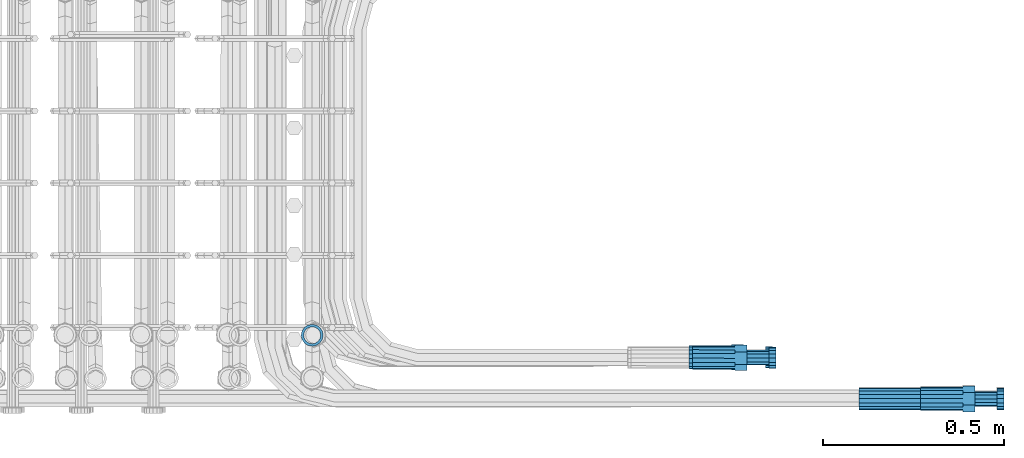
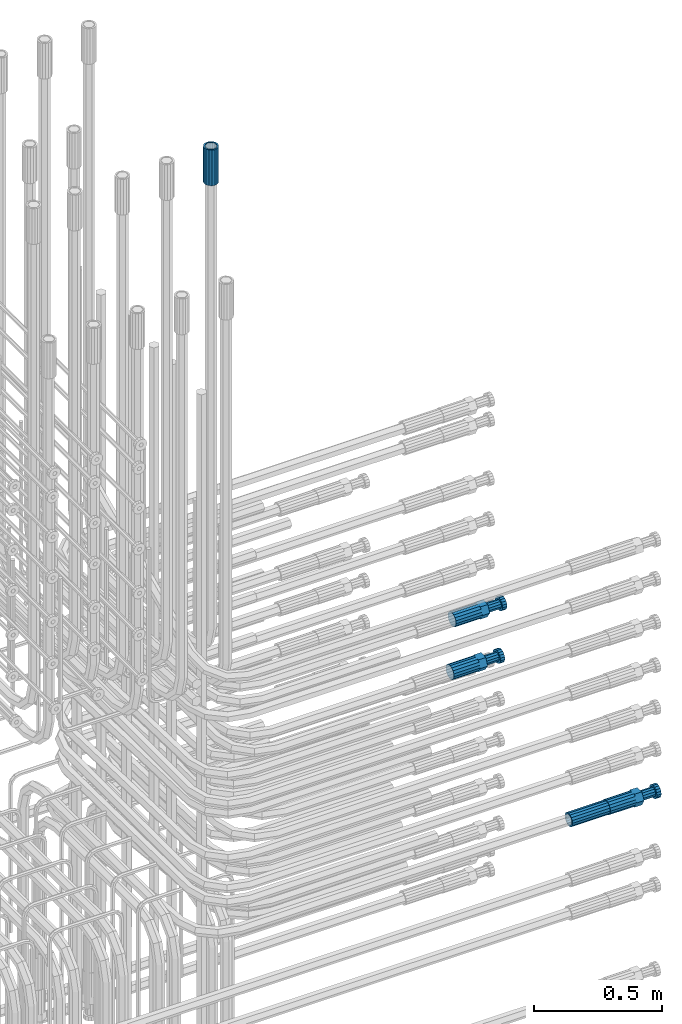
# One storey, part 101 of 177: 5 beams.
"""IFC2X3 building model written with IfcOpenShell, lengths in millimetres."""

from ifc_helpers import new_model, si_unit, frame, origin_with_axes, place, context, subcontext, project, spatial, faceted_brep, material, type_object, element, save


model = new_model("IFC2X3")

# Units and contexts
model_context_1 = context("Model", 3, precision=1e-05, world=origin_with_axes())
model_context_2 = context("Model", 3, precision=1e-05, world=origin_with_axes())
body_context = subcontext(model_context_2, "Body", "Model", "MODEL_VIEW")
ifc_project = project(units=[si_unit("LENGTHUNIT", "METRE", prefix="MILLI"), si_unit("AREAUNIT", "SQUARE_METRE"), si_unit("VOLUMEUNIT", "CUBIC_METRE"), si_unit("MASSUNIT", "GRAM", prefix="KILO"), si_unit("TIMEUNIT", "SECOND"), si_unit("PLANEANGLEUNIT", "RADIAN"), si_unit("SOLIDANGLEUNIT", "STERADIAN"), si_unit("THERMODYNAMICTEMPERATUREUNIT", "DEGREE_CELSIUS"), si_unit("LUMINOUSINTENSITYUNIT", "LUMEN")], contexts=[model_context_1])

# Site, building, storey
site_placement = place(None, origin_with_axes())
site = spatial("IfcSite", under=ifc_project, at=site_placement, CompositionType="ELEMENT")
building_placement = place(site_placement, origin_with_axes())
building = spatial("IfcBuilding", under=site, at=building_placement, Name="Undefined", CompositionType="ELEMENT")
storey_placement = place(building_placement, origin_with_axes())
storey = spatial("IfcBuildingStorey", under=building, at=storey_placement, Name="Undefined", CompositionType="ELEMENT", Elevation=0.0)

# Beams
ifc_material = material(Name="STEEL/S275")
beam_type_1 = type_object("IfcBeamType", PredefinedType="NOTDEFINED")
beam_1_placement = place(storey_placement, frame((2039349.51584447, 6205098.06535392, 19760.1899362774), z_axis=(0.0, -0.0174524050028996, -0.999847695181429), x_axis=(1.0, 0.0, 0.0)))
element("IfcBeam", 1, at=beam_1_placement, inside=storey, type_object=beam_type_1, material=ifc_material, Name="AG40N", context=body_context, shape_type="Brep", body=[
    faceted_brep([(0.0, -23.5000000001164, -9.31322574615479e-10), (0.0, -21.7111690140155, 8.99306066054851), (170.0, -21.7111690140155, 8.99306066054851), (170.0, -23.5, 0.0), (0.0, -16.6170093578839, 16.6170093575493), (170.0, -16.6170093578839, 16.6170093575493), (0.0, -8.99306066057943, 21.7111690137535), (170.0, -8.99306066057943, 21.7111690137535), (0.0, 1.16415321826935e-10, 23.5), (170.0, 0.0, 23.5), (0.0, 8.99306066057943, 21.7111690137535), (170.0, 8.99306066057943, 21.7111690137535), (0.0, 16.6170093578839, 16.6170093575493), (170.0, 16.6170093578839, 16.6170093575493), (0.0, 21.7111690140155, 8.99306066054851), (170.0, 21.7111690140155, 8.99306066054851), (0.0, 23.5000000001164, -9.31322574615479e-10), (170.0, 23.5, 0.0), (0.0, 21.7111690140155, -8.99306066054851), (170.0, 21.7111690140155, -8.99306066054851), (0.0, 16.6170093578839, -16.6170093575493), (170.0, 16.6170093578839, -16.6170093575493), (0.0, 8.99306066057943, -21.7111690137535), (170.0, 8.99306066057943, -21.7111690137535), (0.0, 1.16415321826935e-10, -23.5000000009313), (170.0, 0.0, -23.5), (0.0, -8.99306066057943, -21.7111690137535), (170.0, -8.99306066057943, -21.7111690137535), (0.0, -16.6170093578839, -16.6170093575493), (170.0, -16.6170093578839, -16.6170093575493), (0.0, -21.7111690140155, -8.99306066054851), (170.0, -21.7111690140155, -8.99306066054851), (0.0, -30.5, 0.0), (0.0, -28.1783257415937, -11.6718446873128), (170.0, -28.1783257415937, -11.6718446873128), (170.0, -30.5, 0.0), (0.0, -21.5667568261888, -21.5667568258941), (170.0, -21.5667568261888, -21.5667568258941), (0.0, -11.6718446871346, -28.1783257415518), (170.0, -11.6718446871346, -28.1783257415518), (0.0, 0.0, -30.5), (170.0, 0.0, -30.5), (0.0, 11.6718446871346, -28.1783257415518), (170.0, 11.6718446871346, -28.1783257415518), (0.0, 21.5667568261888, -21.5667568258941), (170.0, 21.5667568261888, -21.5667568258941), (0.0, 28.1783257415937, -11.6718446873128), (170.0, 28.1783257415937, -11.6718446873128), (0.0, 30.5, 0.0), (170.0, 30.5, 0.0), (0.0, 28.1783257415937, 11.6718446873128), (170.0, 28.1783257415937, 11.6718446873128), (0.0, 21.5667568261888, 21.5667568258941), (170.0, 21.5667568261888, 21.5667568258941), (0.0, 11.6718446871346, 28.1783257415518), (170.0, 11.6718446871346, 28.1783257415518), (0.0, 0.0, 30.5), (170.0, 0.0, 30.5), (0.0, -11.6718446871346, 28.1783257415518), (170.0, -11.6718446871346, 28.1783257415518), (0.0, -21.5667568261888, 21.5667568258941), (170.0, -21.5667568261888, 21.5667568258941), (0.0, -28.1783257415937, 11.6718446873128), (170.0, -28.1783257415937, 11.6718446873128)], [[[0, 1, 2, 3]], [[1, 4, 5, 2]], [[4, 6, 7, 5]], [[6, 8, 9, 7]], [[8, 10, 11, 9]], [[10, 12, 13, 11]], [[12, 14, 15, 13]], [[14, 16, 17, 15]], [[16, 18, 19, 17]], [[18, 20, 21, 19]], [[20, 22, 23, 21]], [[22, 24, 25, 23]], [[24, 26, 27, 25]], [[26, 28, 29, 27]], [[28, 30, 31, 29]], [[30, 0, 3, 31]], [[32, 33, 34, 35]], [[33, 36, 37, 34]], [[36, 38, 39, 37]], [[38, 40, 41, 39]], [[40, 42, 43, 41]], [[42, 44, 45, 43]], [[44, 46, 47, 45]], [[46, 48, 49, 47]], [[48, 50, 51, 49]], [[50, 52, 53, 51]], [[52, 54, 55, 53]], [[54, 56, 57, 55]], [[56, 58, 59, 57]], [[58, 60, 61, 59]], [[60, 62, 63, 61]], [[62, 32, 35, 63]], [[37, 39, 41, 43, 45, 47, 49, 51, 53, 55, 57, 59, 61, 63, 35, 34], [5, 7, 9, 11, 13, 15, 17, 19, 21, 23, 25, 27, 29, 31, 3, 2]], [[62, 60, 58, 56, 54, 52, 50, 48, 46, 44, 42, 40, 38, 36, 33, 32], [30, 28, 26, 24, 22, 20, 18, 16, 14, 12, 10, 8, 6, 4, 1, 0]]]),
])
beam_2_placement = place(storey_placement, frame((2037835.98583793, 6205274.18965057, 23229.9909142034), z_axis=(1.0, 0.0, 0.0), x_axis=(0.0, 0.0, 1.0)))
element("IfcBeam", 2, at=beam_2_placement, inside=storey, type_object=beam_type_1, material=ifc_material, Name="AG40N", context=body_context, shape_type="Brep", body=[
    faceted_brep([(0.0, -23.5000000001164, -9.31322574615479e-10), (0.0, -21.7111690140155, 8.99306066054851), (170.0, -21.7111690140155, 8.99306066054851), (170.0, -23.5, 0.0), (0.0, -16.6170093578839, 16.6170093575493), (170.0, -16.6170093578839, 16.6170093575493), (0.0, -8.99306066057943, 21.7111690137535), (170.0, -8.99306066057943, 21.7111690137535), (0.0, 1.16415321826935e-10, 23.5), (170.0, 0.0, 23.5), (0.0, 8.99306066057943, 21.7111690137535), (170.0, 8.99306066057943, 21.7111690137535), (0.0, 16.6170093578839, 16.6170093575493), (170.0, 16.6170093578839, 16.6170093575493), (0.0, 21.7111690140155, 8.99306066054851), (170.0, 21.7111690140155, 8.99306066054851), (0.0, 23.5000000001164, -9.31322574615479e-10), (170.0, 23.5, 0.0), (0.0, 21.7111690140155, -8.99306066054851), (170.0, 21.7111690140155, -8.99306066054851), (0.0, 16.6170093578839, -16.6170093575493), (170.0, 16.6170093578839, -16.6170093575493), (0.0, 8.99306066057943, -21.7111690137535), (170.0, 8.99306066057943, -21.7111690137535), (0.0, 1.16415321826935e-10, -23.5000000009313), (170.0, 0.0, -23.5), (0.0, -8.99306066057943, -21.7111690137535), (170.0, -8.99306066057943, -21.7111690137535), (0.0, -16.6170093578839, -16.6170093575493), (170.0, -16.6170093578839, -16.6170093575493), (0.0, -21.7111690140155, -8.99306066054851), (170.0, -21.7111690140155, -8.99306066054851), (0.0, -30.5, 0.0), (0.0, -28.1783257415937, -11.6718446873128), (170.0, -28.1783257415937, -11.6718446873128), (170.0, -30.5, 0.0), (0.0, -21.5667568261888, -21.5667568258941), (170.0, -21.5667568261888, -21.5667568258941), (0.0, -11.6718446871346, -28.1783257415518), (170.0, -11.6718446871346, -28.1783257415518), (0.0, 0.0, -30.5), (170.0, 0.0, -30.5), (0.0, 11.6718446871346, -28.1783257415518), (170.0, 11.6718446871346, -28.1783257415518), (0.0, 21.5667568261888, -21.5667568258941), (170.0, 21.5667568261888, -21.5667568258941), (0.0, 28.1783257415937, -11.6718446873128), (170.0, 28.1783257415937, -11.6718446873128), (0.0, 30.5, 0.0), (170.0, 30.5, 0.0), (0.0, 28.1783257415937, 11.6718446873128), (170.0, 28.1783257415937, 11.6718446873128), (0.0, 21.5667568261888, 21.5667568258941), (170.0, 21.5667568261888, 21.5667568258941), (0.0, 11.6718446871346, 28.1783257415518), (170.0, 11.6718446871346, 28.1783257415518), (0.0, 0.0, 30.5), (170.0, 0.0, 30.5), (0.0, -11.6718446871346, 28.1783257415518), (170.0, -11.6718446871346, 28.1783257415518), (0.0, -21.5667568261888, 21.5667568258941), (170.0, -21.5667568261888, 21.5667568258941), (0.0, -28.1783257415937, 11.6718446873128), (170.0, -28.1783257415937, 11.6718446873128)], [[[0, 1, 2, 3]], [[1, 4, 5, 2]], [[4, 6, 7, 5]], [[6, 8, 9, 7]], [[8, 10, 11, 9]], [[10, 12, 13, 11]], [[12, 14, 15, 13]], [[14, 16, 17, 15]], [[16, 18, 19, 17]], [[18, 20, 21, 19]], [[20, 22, 23, 21]], [[22, 24, 25, 23]], [[24, 26, 27, 25]], [[26, 28, 29, 27]], [[28, 30, 31, 29]], [[30, 0, 3, 31]], [[32, 33, 34, 35]], [[33, 36, 37, 34]], [[36, 38, 39, 37]], [[38, 40, 41, 39]], [[40, 42, 43, 41]], [[42, 44, 45, 43]], [[44, 46, 47, 45]], [[46, 48, 49, 47]], [[48, 50, 51, 49]], [[50, 52, 53, 51]], [[52, 54, 55, 53]], [[54, 56, 57, 55]], [[56, 58, 59, 57]], [[58, 60, 61, 59]], [[60, 62, 63, 61]], [[62, 32, 35, 63]], [[37, 39, 41, 43, 45, 47, 49, 51, 53, 55, 57, 59, 61, 63, 35, 34], [5, 7, 9, 11, 13, 15, 17, 19, 21, 23, 25, 27, 29, 31, 3, 2]], [[62, 60, 58, 56, 54, 52, 50, 48, 46, 44, 42, 40, 38, 36, 33, 32], [30, 28, 26, 24, 22, 20, 18, 16, 14, 12, 10, 8, 6, 4, 1, 0]]]),
])
beam_type_2 = type_object("IfcBeamType", Name="ROD65", PredefinedType="NOTDEFINED")
beam_3_placement = place(storey_placement, frame((2039519.51584447, 6205098.06535392, 19760.1899362774), z_axis=(0.0, -0.0174524050028996, -0.999847695181429), x_axis=(1.0, 0.0, 0.0)))
element("IfcBeam", 3, at=beam_3_placement, inside=storey, type_object=beam_type_2, material=ifc_material, Name="AGB40", ObjectType="ROD65", context=body_context, shape_type="Brep", body=[
    faceted_brep([(117.0, 8.17543110251427, 30.873805644922), (117.0, 17.8250000001863, 30.873805644922), (117.0, 22.0056958701462, 23.6326279877685), (117.0, 12.4372115517035, 30.0260848065373), (117.0, -17.8250000001863, 30.873805644922), (150.200000000186, -17.8250000001863, 30.873805644922), (150.200000000186, 17.8250000001863, 30.873805644922), (117.0, -8.17543110251427, 30.873805644922), (117.0, -12.4372115517035, 30.0260848065373), (117.0, -22.0056958701462, 23.6326279877685), (117.0, -35.6500000003725, 0.0), (150.200000000186, -35.6500000003725, 0.0), (117.0, -30.8443150008097, 8.32369058486074), (117.0, -32.5, 0.0), (117.0, -30.8443150008097, -8.32369058462791), (117.0, -17.8250000001863, -30.873805644922), (150.200000000186, -17.8250000001863, -30.873805644922), (117.0, -22.0056958701462, -23.6326279877685), (117.0, -12.4372115517035, -30.0260848065373), (117.0, -8.17543110251427, -30.873805644922), (117.0, 17.8250000001863, -30.873805644922), (150.200000000186, 17.8250000001863, -30.873805644922), (117.0, 8.17543110251427, -30.873805644922), (117.0, 22.0056958701462, -23.6326279877685), (117.0, 12.4372115517035, -30.0260848065373), (117.0, 35.6500000003725, 0.0), (150.200000000186, 35.6500000003725, 0.0), (117.0, 30.8443150008097, -8.32369058486074), (117.0, 30.8443150008097, 8.32369058462791), (117.0, 32.5, 0.0), (0.0, -22.9809703892097, 22.9809703885621), (0.0, -30.0260848058388, 12.4372115518636), (117.0, -30.0260848067701, 12.4372115519363), (117.0, -22.9809703882784, 22.9809703885112), (-2.3283064365387e-10, 22.9809703892097, -22.9809703885639), (-4.65661287307739e-10, 30.0260848077014, -12.4372115518672), (117.0, 30.0260848067701, -12.4372115519363), (117.0, 22.9809703882784, -22.9809703885112), (-2.3283064365387e-10, -30.0260848067701, -12.4372115518672), (-2.3283064365387e-10, -22.9809703892097, -22.9809703885621), (117.0, -22.9809703882784, -22.9809703885112), (117.0, -30.0260848067701, -12.4372115519363), (-2.3283064365387e-10, -12.4372115507722, 30.0260848066137), (-2.3283064365387e-10, 9.31322574615479e-10, 32.4999999999982), (-2.3283064365387e-10, 12.4372115526348, 30.0260848066137), (0.0, 22.9809703892097, 22.9809703885621), (-2.3283064365387e-10, 30.0260848077014, 12.4372115518636), (-2.3283064365387e-10, 32.5, 0.0), (-2.3283064365387e-10, 12.4372115526348, -30.0260848066173), (-2.3283064365387e-10, 9.31322574615479e-10, -32.5), (-2.3283064365387e-10, -12.4372115517035, -30.0260848066173), (-4.65661287307739e-10, -32.4999999990687, -1.81898940354586e-12), (117.0, 22.9809703882784, 22.9809703885112), (117.0, 30.0260848067701, 12.4372115519363), (117.0, 0.0, -32.5), (117.0, 0.0, 32.5), (150.200000000186, 10.5, -18.1865334794857), (150.200000000186, 0.0, -21.0), (150.200000000186, -10.5, -18.1865334794857), (150.200000000186, -18.18653347902, -10.5), (150.200000000186, -21.0, 0.0), (150.200000000186, -18.18653347902, 10.5), (150.200000000186, -10.5, 18.1865334794857), (150.200000000186, 0.0, 21.0), (150.200000000186, 10.5, 18.1865334794857), (150.200000000186, 18.18653347902, 10.5), (150.200000000186, 21.0, 0.0), (150.200000000186, 18.18653347902, -10.5), (210.980000000447, -18.18653347902, 10.5), (210.980000000447, -21.0, 0.0), (210.980000000447, -10.5, 18.1865334794857), (210.980000000447, 0.0, 21.0), (210.980000000447, 10.5, 18.1865334794857), (210.980000000447, 18.18653347902, 10.5), (210.980000000447, 21.0, 0.0), (210.980000000447, 18.18653347902, -10.5), (210.980000000447, 10.5, -18.1865334794857), (210.980000000447, 0.0, -21.0), (210.980000000447, -10.5, -18.1865334794857), (210.980000000447, -18.18653347902, -10.5), (211.001368442696, -27.7269937992096, -11.491116326768), (211.003082550167, -21.2238094303757, -21.223815418547), (231.002518367059, -21.2131944671273, -21.2132004550658), (231.000804259587, -27.7163788359612, -11.4805013632867), (211.001368440451, -11.4911085031927, -27.7269970395137), (231.000804257343, -11.4804935399443, -27.7163820760325), (210.996487071217, -0.0106065049767494, -30.0106107392348), (230.995922888109, 8.45827162265778e-06, -29.9999957757536), (210.989181586672, 11.46989420522, -27.7269970329944), (230.988617403564, 11.4805091684684, -27.7163820695132), (210.980564180623, 21.2025914648548, -21.2238154064398), (230.979999997515, 21.2132064281031, -21.2132004429586), (210.971946775022, 27.7057703435421, -11.4911163107026), (230.971382591913, 27.7163853067905, -11.4805013472214), (210.96464129175, 29.9893808094785, -0.0106149562634528), (230.964077108642, 29.9999957727268, 7.21774995326996e-09), (210.959759924415, 27.7057638689876, 11.4698863970116), (230.959195741307, 27.7163788322359, 11.4805013604928), (210.958045816944, 21.2025795001537, 21.2025854887906), (230.957481633835, 21.213194463402, 21.2132004522718), (210.95975992666, 11.4698785729706, 27.7057671097573), (230.959195743551, 11.480493536219, 27.7163820732385), (210.964641295894, -0.010623425245285, 29.9893808094785), (230.964077112785, -8.46199691295624e-06, 29.9999957729597), (210.971946780439, -11.4911241354421, 27.705767103238), (230.97138259733, -11.4805091721937, 27.7163820667192), (210.980564186488, -21.2238213950768, 21.2025854766835), (230.980000003379, -21.2132064318284, 21.2132004401647), (210.989181592089, -27.7270002737641, 11.4698863809463), (230.988617408981, -27.7163853105158, 11.4805013444275), (210.996487075361, -30.0106107397005, -0.0106149734929204), (230.995922892253, -29.9999957764521, -1.00117176771164e-08)], [[[0, 1, 2, 3]], [[4, 5, 6, 1, 0, 7]], [[4, 7, 8, 9]], [[10, 11, 5, 4, 9, 12]], [[10, 12, 13, 14]], [[15, 16, 11, 10, 14, 17]], [[15, 17, 18, 19]], [[20, 21, 16, 15, 19, 22]], [[23, 20, 22, 24]], [[25, 26, 21, 20, 23, 27]], [[28, 25, 27, 29]], [[30, 31, 32, 33]], [[34, 35, 36, 37]], [[38, 39, 40, 41]], [[31, 30, 42, 43, 44, 45, 46, 47, 35, 34, 48, 49, 50, 39, 38, 51]], [[46, 45, 52, 53]], [[29, 47, 46, 53, 28]], [[27, 36, 35, 47, 29]], [[23, 37, 36, 27]], [[24, 48, 34, 37, 23]], [[22, 54, 49, 48, 24]], [[19, 54, 22]], [[18, 50, 49, 54, 19]], [[17, 40, 39, 50, 18]], [[14, 41, 40, 17]], [[13, 51, 38, 41, 14]], [[12, 32, 31, 51, 13]], [[9, 33, 32, 12]], [[8, 42, 30, 33, 9]], [[7, 55, 43, 42, 8]], [[0, 55, 7]], [[3, 44, 43, 55, 0]], [[2, 52, 45, 44, 3]], [[28, 53, 52, 2]], [[1, 6, 26, 25, 28, 2]], [[5, 11, 16, 21, 26, 6], [56, 57, 58, 59, 60, 61, 62, 63, 64, 65, 66, 67]], [[68, 61, 60, 69]], [[70, 62, 61, 68]], [[71, 63, 62, 70]], [[72, 64, 63, 71]], [[73, 65, 64, 72]], [[74, 66, 65, 73]], [[75, 67, 66, 74]], [[76, 56, 67, 75]], [[77, 57, 56, 76]], [[78, 58, 57, 77]], [[79, 59, 58, 78]], [[69, 60, 59, 79]], [[80, 81, 82, 83]], [[81, 84, 85, 82]], [[84, 86, 87, 85]], [[86, 88, 89, 87]], [[88, 90, 91, 89]], [[90, 92, 93, 91]], [[92, 94, 95, 93]], [[94, 96, 97, 95]], [[96, 98, 99, 97]], [[98, 100, 101, 99]], [[100, 102, 103, 101]], [[102, 104, 105, 103]], [[104, 106, 107, 105]], [[106, 108, 109, 107]], [[108, 110, 111, 109]], [[82, 85, 87, 89, 91, 93, 95, 97, 99, 101, 103, 105, 107, 109, 111, 83]], [[110, 80, 83, 111]], [[108, 106, 104, 102, 100, 98, 96, 94, 92, 90, 88, 86, 84, 81, 80, 110], [75, 74, 73, 72, 71, 70, 68, 69, 79, 78, 77, 76]]]),
])
beam_4_placement = place(storey_placement, frame((2038888.72878909, 6205212.48943585, 20808.5915860885), z_axis=(0.000433569077169531, 0.0540233269836764, -0.998539579665959), x_axis=(0.999999540135183, -0.000877596002081451, 0.000386723000056089)))
element("IfcBeam", 4, at=beam_4_placement, inside=storey, type_object=beam_type_2, material=ifc_material, Name="AGB40", ObjectType="ROD65", context=body_context, shape_type="Brep", body=[
    faceted_brep([(117.000070887152, 17.8246290590614, 30.8726634858758), (117.000062540872, 22.0040183886886, 23.6337488439167), (117.0, 12.4372115517035, 30.0260848065373), (117.00006474345, 8.18117318674922, 30.8726634728373), (117.000048175221, -17.8253709422424, 30.8726634376217), (150.200048082275, -17.8253920935094, 30.8726129469578), (150.200070794206, 17.8246079077944, 30.8726129952702), (117.000054319389, -8.18117330409586, 30.8726634507184), (117.0, -12.4372115517035, 30.0260848065373), (117.000034502242, -22.0052261305973, 23.632941858843), (116.999989866046, -35.6503708986565, -0.00114223139826208), (150.199989773333, -35.6503920508549, -0.00119272212032229), (117.000005587237, -30.8444666713476, 8.32292809523642), (117.0, -32.5, 0.0), (116.999999676365, -30.8437734348699, -8.32641322480049), (116.999954269035, -17.8253708574921, -30.8749478521058), (150.199954176089, -17.8253920087591, -30.8749983428279), (116.999962620437, -22.0073733022436, -23.6315071650315), (116.99996042042, -8.16968890745193, -30.8749478390091), (117.0, -12.4372115517035, -30.0260848065373), (116.999976980966, 17.8246291419491, -30.8749478038517), (150.199976888252, 17.8246079906821, -30.8749982945155), (116.999970830046, 8.16968901548535, -30.8749478169484), (116.999990659533, 22.0061656553298, -23.6323140860768), (117.0, 12.4372115517035, -30.0260848065373), (117.000035289908, 35.6496291011572, -0.00114213483175263), (150.200035197195, 35.6496079498902, -0.00119262543739751), (117.000019570114, 30.8441633442417, -8.32445300510153), (117.0, 32.5, 0.0), (117.000044885324, 30.8448565527797, 8.32096801092848), (0.0, -22.9809703892097, 22.9809703885621), (0.0, -30.0260848058388, 12.4372115518636), (117.0, -30.0260848067701, 12.4372115519363), (117.0, -22.9809703882784, 22.9809703885112), (-2.3283064365387e-10, 22.9809703892097, -22.9809703885639), (-4.65661287307739e-10, 30.0260848077014, -12.4372115518672), (117.0, 30.0260848067701, -12.4372115519363), (117.0, 22.9809703882784, -22.9809703885112), (-2.3283064365387e-10, -30.0260848067701, -12.4372115518672), (-2.3283064365387e-10, -22.9809703892097, -22.9809703885621), (117.0, -22.9809703882784, -22.9809703885112), (117.0, -30.0260848067701, -12.4372115519363), (-2.3283064365387e-10, -12.4372115507722, 30.0260848066137), (-2.3283064365387e-10, 9.31322574615479e-10, 32.4999999999982), (-2.3283064365387e-10, 12.4372115526348, 30.0260848066137), (0.0, 22.9809703892097, 22.9809703885621), (-2.3283064365387e-10, 30.0260848077014, 12.4372115518636), (-2.3283064365387e-10, 32.5, 0.0), (-2.3283064365387e-10, 12.4372115526348, -30.0260848066173), (-2.3283064365387e-10, 9.31322574615479e-10, -32.5), (-2.3283064365387e-10, -12.4372115517035, -30.0260848066173), (-4.65661287307739e-10, -32.4999999990687, -1.81898940354586e-12), (117.0, 22.9809703882784, 22.9809703885112), (117.0, 30.0260848067701, 12.4372115519363), (117.0, 0.0, -32.5), (117.0, 0.0, 32.5), (150.200000000186, 10.5, -18.1865334794857), (150.200000000186, 0.0, -21.0), (150.200000000186, -10.5, -18.1865334794857), (150.200000000186, -18.18653347902, -10.5), (150.200000000186, -21.0, 0.0), (150.200000000186, -18.18653347902, 10.5), (150.200000000186, -10.5, 18.1865334794857), (150.200000000186, 0.0, 21.0), (150.200000000186, 10.5, 18.1865334794857), (150.200000000186, 18.18653347902, 10.5), (150.200000000186, 21.0, 0.0), (150.200000000186, 18.18653347902, -10.5), (210.980000000447, -18.18653347902, 10.5), (210.980000000447, -21.0, 0.0), (210.980000000447, -10.5, 18.1865334794857), (210.980000000447, 0.0, 21.0), (210.980000000447, 10.5, 18.1865334794857), (210.980000000447, 18.18653347902, 10.5), (210.980000000447, 21.0, 0.0), (210.980000000447, 18.18653347902, -10.5), (210.980000000447, 10.5, -18.1865334794857), (210.980000000447, 0.0, -21.0), (210.980000000447, -10.5, -18.1865334794857), (210.980000000447, -18.18653347902, -10.5), (211.001508464553, -27.7271681446582, -11.4909390010871), (211.003079450442, -21.2239838149399, -21.2236381415278), (231.002518367059, -21.2131944671273, -21.2132004550658), (231.000944282579, -27.7163786357269, -11.4805015055463), (211.001222690906, -11.4912829371169, -27.7268197983503), (231.000658508932, -11.4804934263229, -27.7163823025767), (210.996220860747, -0.0107809938490391, -30.0104335148353), (230.995656678773, 8.51508229970932e-06, -29.9999960190617), (210.98883544327, 11.4697196632624, -27.7268198039383), (230.988271261296, 11.4805091740564, -27.7163823083974), (210.980190801332, 21.2024168828502, -21.223638152238), (230.979626619359, 21.2132063927129, -21.21320065693), (210.971603003305, 27.7055957382545, -11.4909390148241), (230.971038821335, 27.7163852481171, -11.4805015192833), (210.964379463599, 29.9892062013969, -0.0104376077651978), (230.963815281626, 29.9999957103282, -1.12224370241165e-07), (210.959619900637, 27.7055892786011, 11.4700638004579), (230.959055718664, 27.7163787893951, 11.4805012957659), (210.958048914752, 21.2024049470201, 21.2027629411314), (230.957481633835, 21.213194463402, 21.2132004522718), (210.959905674285, 11.4697040701285, 27.7059445977211), (230.959341492311, 11.4804935790598, 27.7163820932619), (210.964907504444, -0.0107978722080588, 29.9895583142061), (230.96434332247, -8.36141407489777e-06, 29.9999958095141), (210.972292921921, -11.4912985311821, 27.7059446035419), (230.971728739951, -11.4805090194568, 27.7163820988499), (210.980937563858, -21.2239957498387, 21.2027629516087), (230.980373381884, -21.213206239976, 21.2132004473824), (210.989525361885, -27.7271746052429, 11.4700638141949), (230.988961179912, -27.7163850944489, 11.4805013095029), (210.996748901591, -30.0107850683853, -0.0104375926312059), (230.996184719621, -29.9999955575913, -9.73232090473175e-08)], [[[0, 1, 2, 3]], [[4, 5, 6, 0, 3, 7]], [[4, 7, 8, 9]], [[10, 11, 5, 4, 9, 12]], [[10, 12, 13, 14]], [[15, 16, 11, 10, 14, 17]], [[18, 15, 17, 19]], [[20, 21, 16, 15, 18, 22]], [[23, 20, 22, 24]], [[25, 26, 21, 20, 23, 27]], [[25, 27, 28, 29]], [[30, 31, 32, 33]], [[34, 35, 36, 37]], [[38, 39, 40, 41]], [[31, 30, 42, 43, 44, 45, 46, 47, 35, 34, 48, 49, 50, 39, 38, 51]], [[46, 45, 52, 53]], [[28, 47, 46, 53, 29]], [[27, 36, 35, 47, 28]], [[23, 37, 36, 27]], [[24, 48, 34, 37, 23]], [[22, 54, 49, 48, 24]], [[18, 54, 22]], [[19, 50, 49, 54, 18]], [[17, 40, 39, 50, 19]], [[14, 41, 40, 17]], [[13, 51, 38, 41, 14]], [[12, 32, 31, 51, 13]], [[9, 33, 32, 12]], [[8, 42, 30, 33, 9]], [[7, 55, 43, 42, 8]], [[3, 55, 7]], [[2, 44, 43, 55, 3]], [[1, 52, 45, 44, 2]], [[29, 53, 52, 1]], [[0, 6, 26, 25, 29, 1]], [[5, 11, 16, 21, 26, 6], [56, 57, 58, 59, 60, 61, 62, 63, 64, 65, 66, 67]], [[68, 61, 60, 69]], [[70, 62, 61, 68]], [[71, 63, 62, 70]], [[72, 64, 63, 71]], [[73, 65, 64, 72]], [[74, 66, 65, 73]], [[75, 67, 66, 74]], [[76, 56, 67, 75]], [[77, 57, 56, 76]], [[78, 58, 57, 77]], [[79, 59, 58, 78]], [[69, 60, 59, 79]], [[80, 81, 82, 83]], [[81, 84, 85, 82]], [[84, 86, 87, 85]], [[86, 88, 89, 87]], [[88, 90, 91, 89]], [[90, 92, 93, 91]], [[92, 94, 95, 93]], [[94, 96, 97, 95]], [[96, 98, 99, 97]], [[98, 100, 101, 99]], [[100, 102, 103, 101]], [[102, 104, 105, 103]], [[104, 106, 107, 105]], [[106, 108, 109, 107]], [[108, 110, 111, 109]], [[82, 85, 87, 89, 91, 93, 95, 97, 99, 101, 103, 105, 107, 109, 111, 83]], [[110, 80, 83, 111]], [[108, 106, 104, 102, 100, 98, 96, 94, 92, 90, 88, 86, 84, 81, 80, 110], [75, 74, 73, 72, 71, 70, 68, 69, 79, 78, 77, 76]]]),
])
beam_5_placement = place(storey_placement, frame((2038879.51030979, 6205213.00890399, 20559.679724903), z_axis=(0.00101999371475544, 0.094140996011909, -0.995558352123424), x_axis=(0.999999429546481, 0.000219617000317828, 0.00104531099952911)))
element("IfcBeam", 5, at=beam_5_placement, inside=storey, type_object=beam_type_2, material=ifc_material, Name="AGB40", ObjectType="ROD65", context=body_context, shape_type="Brep", body=[
    faceted_brep([(117.0, 17.8250551465899, 30.8738780597196), (117.0, 22.0058537181467, 23.63252251636), (117.0, 12.4372115517035, 30.0260848065373), (117.0, 8.17506704945117, 30.8738780597196), (117.0, -17.8249448528513, 30.873878059705), (150.200000000186, -17.8249448528513, 30.873878059705), (150.200000000186, 17.8250551465899, 30.8738780597196), (117.0, -8.17506705131382, 30.873878059705), (117.0, -12.4372115517035, 30.0260848065373), (116.99999886984, -22.0056591425091, 23.6326525291661), (117.0, -35.6499448539689, 7.24148121662438e-05), (150.200000000186, -35.6499448539689, 7.24148121662438e-05), (116.999998904532, -30.8443268593401, 8.32363097346388), (117.0, -32.5, 0.0), (117.000000157394, -30.8443746902049, -8.32339051074814), (117.0, -17.8249448537827, -30.8737332301098), (150.200000000186, -17.8249448537827, -30.8737332301098), (117.0, -22.0055380193517, -23.6327334611997), (117.0, -8.17579515744001, -30.8737332301098), (117.0, -12.4372115517035, -30.0260848065373), (117.0, 17.8250551456586, -30.8737332301098), (150.200000000186, 17.8250551456586, -30.8737332301098), (117.0, 8.17579515557736, -30.8737332301098), (116.999999235384, 22.0057325940579, -23.6326034488156), (117.0, 12.4372115517035, -30.0260848065373), (117.0, 35.6500551467761, 7.24147976143286e-05), (150.200000000186, 35.6500551467761, 7.24147976143286e-05), (116.999999200692, 30.8443031422794, -8.32375019358005), (117.0, 32.5, 0.0), (116.999999127816, 30.8442553114146, 8.32399065606296), (0.0, -22.9809703892097, 22.9809703885621), (0.0, -30.0260848058388, 12.4372115518636), (117.0, -30.0260848067701, 12.4372115519363), (117.0, -22.9809703882784, 22.9809703885112), (-2.3283064365387e-10, 22.9809703892097, -22.9809703885639), (-4.65661287307739e-10, 30.0260848077014, -12.4372115518672), (117.0, 30.0260848067701, -12.4372115519363), (117.0, 22.9809703882784, -22.9809703885112), (-2.3283064365387e-10, -30.0260848067701, -12.4372115518672), (-2.3283064365387e-10, -22.9809703892097, -22.9809703885621), (117.0, -22.9809703882784, -22.9809703885112), (117.0, -30.0260848067701, -12.4372115519363), (-2.3283064365387e-10, -12.4372115507722, 30.0260848066137), (-2.3283064365387e-10, 9.31322574615479e-10, 32.4999999999982), (-2.3283064365387e-10, 12.4372115526348, 30.0260848066137), (0.0, 22.9809703892097, 22.9809703885621), (-2.3283064365387e-10, 30.0260848077014, 12.4372115518636), (-2.3283064365387e-10, 32.5, 0.0), (-2.3283064365387e-10, 12.4372115526348, -30.0260848066173), (-2.3283064365387e-10, 9.31322574615479e-10, -32.5), (-2.3283064365387e-10, -12.4372115517035, -30.0260848066173), (-4.65661287307739e-10, -32.4999999990687, -1.81898940354586e-12), (117.0, 22.9809703882784, 22.9809703885112), (117.0, 30.0260848067701, 12.4372115519363), (117.0, 0.0, -32.5), (117.0, 0.0, 32.5), (150.200000000186, 10.5, -18.1865334794857), (150.200000000186, 0.0, -21.0), (150.200000000186, -10.5, -18.1865334794857), (150.200000000186, -18.18653347902, -10.5), (150.200000000186, -21.0, 0.0), (150.200000000186, -18.18653347902, 10.5), (150.200000000186, -10.5, 18.1865334794857), (150.200000000186, 0.0, 21.0), (150.200000000186, 10.5, 18.1865334794857), (150.200000000186, 18.18653347902, 10.5), (150.200000000186, 21.0, 0.0), (150.200000000186, 18.18653347902, -10.5), (210.980000000447, -18.18653347902, 10.5), (210.980000000447, -21.0, 0.0), (210.980000000447, -10.5, 18.1865334794857), (210.980000000447, 0.0, 21.0), (210.980000000447, 10.5, 18.1865334794857), (210.980000000447, 18.18653347902, 10.5), (210.980000000447, 21.0, 0.0), (210.980000000447, 18.18653347902, -10.5), (210.980000000447, 10.5, -18.1865334794857), (210.980000000447, 0.0, -21.0), (210.980000000447, -10.5, -18.1865334794857), (210.980000000447, -18.18653347902, -10.5), (211.001368442696, -27.7269937992096, -11.491116326768), (211.003082550167, -21.2238094303757, -21.223815418547), (231.002518367059, -21.2131944671273, -21.2132004550658), (231.000804259587, -27.7163788359612, -11.4805013632867), (211.001368440451, -11.4911085031927, -27.7269970395137), (231.000804257343, -11.4804935399443, -27.7163820760325), (210.996487071217, -0.0106065049767494, -30.0106107392348), (230.995922888109, 8.45827162265778e-06, -29.9999957757536), (210.989181586672, 11.46989420522, -27.7269970329944), (230.988617403564, 11.4805091684684, -27.7163820695132), (210.980564180623, 21.2025914648548, -21.2238154064398), (230.979999997515, 21.2132064281031, -21.2132004429586), (210.971946775022, 27.7057703435421, -11.4911163107026), (230.971382591913, 27.7163853067905, -11.4805013472214), (210.96464129175, 29.9893808094785, -0.0106149562634528), (230.964077108642, 29.9999957727268, 7.21774995326996e-09), (210.959759924415, 27.7057638689876, 11.4698863970116), (230.959195741307, 27.7163788322359, 11.4805013604928), (210.958045816944, 21.2025795001537, 21.2025854887906), (230.957481633835, 21.213194463402, 21.2132004522718), (210.95975992666, 11.4698785729706, 27.7057671097573), (230.959195743551, 11.480493536219, 27.7163820732385), (210.964641295894, -0.010623425245285, 29.9893808094785), (230.964077112785, -8.46199691295624e-06, 29.9999957729597), (210.971946780439, -11.4911241354421, 27.705767103238), (230.97138259733, -11.4805091721937, 27.7163820667192), (210.980564186488, -21.2238213950768, 21.2025854766835), (230.980000003379, -21.2132064318284, 21.2132004401647), (210.989181592089, -27.7270002737641, 11.4698863809463), (230.988617408981, -27.7163853105158, 11.4805013444275), (210.996487075361, -30.0106107397005, -0.0106149734929204), (230.995922892253, -29.9999957764521, -1.00117176771164e-08)], [[[0, 1, 2, 3]], [[4, 5, 6, 0, 3, 7]], [[4, 7, 8, 9]], [[10, 11, 5, 4, 9, 12]], [[10, 12, 13, 14]], [[15, 16, 11, 10, 14, 17]], [[18, 15, 17, 19]], [[20, 21, 16, 15, 18, 22]], [[23, 20, 22, 24]], [[25, 26, 21, 20, 23, 27]], [[25, 27, 28, 29]], [[30, 31, 32, 33]], [[34, 35, 36, 37]], [[38, 39, 40, 41]], [[31, 30, 42, 43, 44, 45, 46, 47, 35, 34, 48, 49, 50, 39, 38, 51]], [[46, 45, 52, 53]], [[28, 47, 46, 53, 29]], [[27, 36, 35, 47, 28]], [[23, 37, 36, 27]], [[24, 48, 34, 37, 23]], [[22, 54, 49, 48, 24]], [[18, 54, 22]], [[19, 50, 49, 54, 18]], [[17, 40, 39, 50, 19]], [[14, 41, 40, 17]], [[13, 51, 38, 41, 14]], [[12, 32, 31, 51, 13]], [[9, 33, 32, 12]], [[8, 42, 30, 33, 9]], [[7, 55, 43, 42, 8]], [[3, 55, 7]], [[2, 44, 43, 55, 3]], [[1, 52, 45, 44, 2]], [[29, 53, 52, 1]], [[0, 6, 26, 25, 29, 1]], [[5, 11, 16, 21, 26, 6], [56, 57, 58, 59, 60, 61, 62, 63, 64, 65, 66, 67]], [[68, 61, 60, 69]], [[70, 62, 61, 68]], [[71, 63, 62, 70]], [[72, 64, 63, 71]], [[73, 65, 64, 72]], [[74, 66, 65, 73]], [[75, 67, 66, 74]], [[76, 56, 67, 75]], [[77, 57, 56, 76]], [[78, 58, 57, 77]], [[79, 59, 58, 78]], [[69, 60, 59, 79]], [[80, 81, 82, 83]], [[81, 84, 85, 82]], [[84, 86, 87, 85]], [[86, 88, 89, 87]], [[88, 90, 91, 89]], [[90, 92, 93, 91]], [[92, 94, 95, 93]], [[94, 96, 97, 95]], [[96, 98, 99, 97]], [[98, 100, 101, 99]], [[100, 102, 103, 101]], [[102, 104, 105, 103]], [[104, 106, 107, 105]], [[106, 108, 109, 107]], [[108, 110, 111, 109]], [[82, 85, 87, 89, 91, 93, 95, 97, 99, 101, 103, 105, 107, 109, 111, 83]], [[110, 80, 83, 111]], [[108, 106, 104, 102, 100, 98, 96, 94, 92, 90, 88, 86, 84, 81, 80, 110], [75, 74, 73, 72, 71, 70, 68, 69, 79, 78, 77, 76]]]),
])

save(model, "model.ifc")
